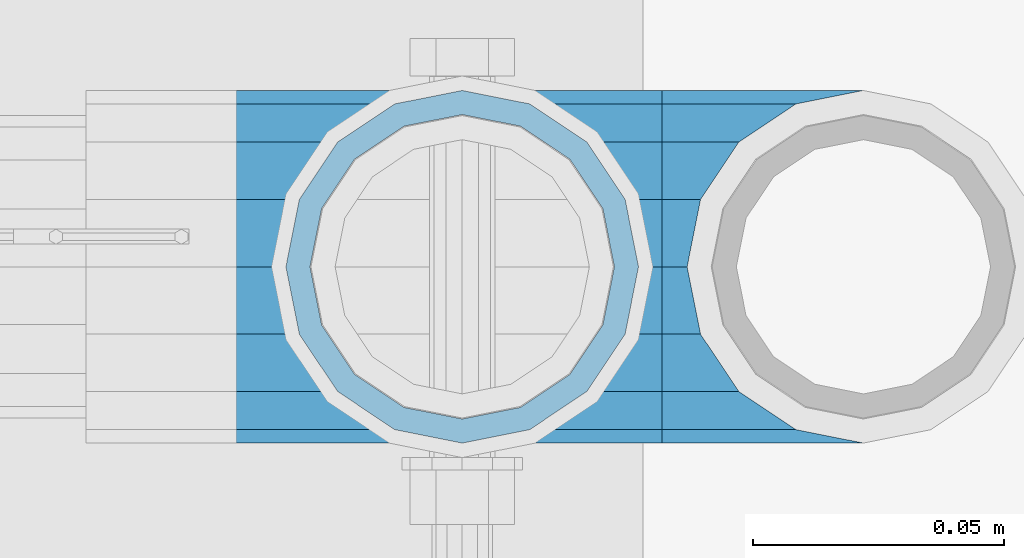
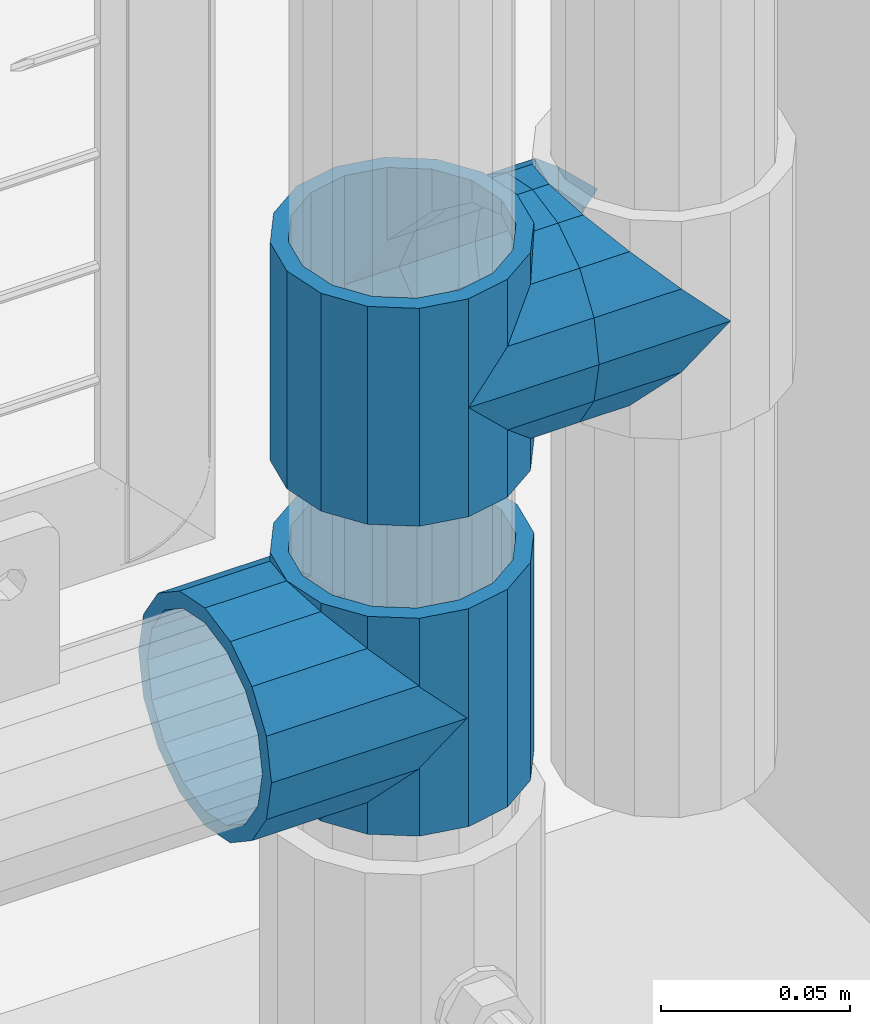
# One storey, part 171 of 247: 5 beams.
"""IFC2X3 building model written with IfcOpenShell, lengths in millimetres."""

from ifc_helpers import new_model, si_unit, frame, origin_with_axes, place, context, subcontext, project, spatial, faceted_brep, material, type_object, element, save


model = new_model("IFC2X3")

# Units and contexts
model_context = context("Model", 3, precision=1e-05, world=origin_with_axes())
body_context = subcontext(model_context, "Body", "Model", "MODEL_VIEW")
ifc_project = project(units=[si_unit("LENGTHUNIT", "METRE", prefix="MILLI"), si_unit("AREAUNIT", "SQUARE_METRE"), si_unit("VOLUMEUNIT", "CUBIC_METRE"), si_unit("MASSUNIT", "GRAM", prefix="KILO"), si_unit("TIMEUNIT", "SECOND"), si_unit("PLANEANGLEUNIT", "RADIAN"), si_unit("SOLIDANGLEUNIT", "STERADIAN"), si_unit("THERMODYNAMICTEMPERATUREUNIT", "DEGREE_CELSIUS"), si_unit("LUMINOUSINTENSITYUNIT", "LUMEN")], contexts=[model_context])

# Site, building, storey
site_placement = place(None, origin_with_axes())
site = spatial("IfcSite", under=ifc_project, at=site_placement, CompositionType="ELEMENT")
building_placement = place(site_placement, origin_with_axes())
building = spatial("IfcBuilding", under=site, at=building_placement, Name="Standard", CompositionType="ELEMENT")
storey_placement = place(building_placement, origin_with_axes())
storey = spatial("IfcBuildingStorey", under=building, at=storey_placement, Name="Undefined", CompositionType="ELEMENT", Elevation=0.0)

# Beams
ifc_material = material(Name="Misc_Undefined")
beam_type = type_object("IfcBeamType", PredefinedType="NOTDEFINED")
beam_1_placement = place(storey_placement, frame((16221.0, 7664.5, 298.670000000001), z_axis=(0.0, 1.0, 0.0), x_axis=(-1.0, 0.0, 0.0)))
element("IfcBeam", 1, at=beam_1_placement, inside=storey, type_object=beam_type, material=ifc_material, context=body_context, shape_type="Brep", body=[
    faceted_brep([(0.0, 0.0, -35.1499999999996), (13.4513226476338, -13.4513226476329, -32.4743655677721), (13.4513226476338, 13.4513226476329, -32.4743655677721), (27.1226768591096, -21.4606908090117, 21.4606908090118), (32.4743655677721, -26.8123795176755, 13.4513226476329), (32.4743655677721, -32.4743655677717, 13.4513226476329), (24.8548033587067, -24.8548033587072, 24.8548033587067), (24.8548033587067, -16.3810424080045, 24.8548033587067), (32.8397438117172, -28.0397438117175, 11.6144421722802), (35.1499999999996, -30.35, 0.0), (35.1499999999996, -35.15, 0.0), (32.4743655677721, -26.8123795176766, -13.4513226476329), (32.4743655677721, -32.4743655677717, -13.4513226476329), (32.8397438117172, -28.0397438117175, -11.6144421722802), (24.8548033587067, -16.3810424080045, -24.8548033587067), (24.8548033587067, -24.8548033587072, -24.8548033587067), (27.1226768591059, -21.4606908090117, -21.4606908090118), (20.0882031229885, -11.6144421722805, -28.0397438117179), (16.6306603983739, 0.0, -30.3500000000004), (20.0882031229885, 11.6144421722805, -28.0397438117179), (24.8548033587067, 16.3810424080029, -24.8548033587067), (24.8548033587067, 24.8548033587072, -24.8548033587067), (27.1226768591059, 21.4606908090117, -21.4606908090118), (32.4743655677721, 26.8123795176755, -13.4513226476329), (32.4743655677721, 32.4743655677717, -13.4513226476329), (32.8397438117172, 28.0397438117175, -11.6144421722802), (35.1499999999996, 30.35, 0.0), (35.1499999999996, 35.15, 0.0), (32.8397438117172, 28.0397438117175, 11.6144421722802), (32.4743655677721, 26.8123795176755, 13.4513226476329), (32.4743655677721, 32.4743655677717, 13.4513226476329), (27.1226768591096, 21.4606908090117, 21.4606908090118), (24.8548033587067, 16.3810424080046, 24.8548033587067), (24.8548033587067, 24.8548033587072, 24.8548033587067), (0.0, 0.0, 35.1499999999996), (13.4513226476338, 13.4513226476329, 32.4743655677721), (13.4513226476338, -13.4513226476329, 32.4743655677721), (20.0882031229812, 11.6144421722805, 28.0397438117179), (16.6306603983649, 0.0, 30.3500000000004), (20.0882031229812, -11.6144421722805, 28.0397438117179), (60.1499999999996, -35.15, 0.0), (60.1499999999996, -32.4743655677717, 13.4513226476329), (60.1499999999996, -24.8548033587072, 24.8548033587067), (60.1499999999996, -13.4513226476329, 32.4743655677721), (60.1499999999996, 0.0, 35.1499999999996), (60.1499999999996, -24.8548033587072, -24.8548033587067), (60.1499999999996, -32.4743655677717, -13.4513226476329), (60.1499999999996, -13.4513226476329, -32.4743655677721), (60.1499999999996, 0.0, -35.1499999999996), (60.1499999999996, 13.4513226476329, -32.4743655677721), (60.1499999999996, 24.8548033587072, -24.8548033587067), (60.1499999999996, 32.4743655677717, -13.4513226476329), (60.1499999999996, 35.15, 0.0), (60.1499999999996, 32.4743655677717, 13.4513226476329), (60.1499999999996, 24.8548033587072, 24.8548033587067), (60.1499999999996, 13.4513226476329, 32.4743655677721), (60.1499999999996, -21.4606908090117, 21.4606908090118), (60.1499999999996, -11.6144421722805, 28.0397438117179), (60.1499999999996, 0.0, 30.3500000000004), (60.1499999999996, 11.6144421722805, 28.0397438117179), (60.1499999999996, 21.4606908090117, 21.4606908090118), (60.1499999999996, 28.0397438117175, 11.6144421722802), (60.1499999999996, 30.35, 0.0), (60.1499999999996, 28.0397438117175, -11.6144421722802), (60.1499999999996, 21.4606908090117, -21.4606908090118), (60.1499999999996, 11.6144421722805, -28.0397438117179), (60.1499999999996, 0.0, -30.3500000000004), (60.1499999999996, -11.6144421722805, -28.0397438117179), (60.1499999999996, -21.4606908090117, -21.4606908090118), (60.1499999999996, -28.0397438117175, -11.6144421722802), (60.1499999999996, -30.35, 0.0), (60.1499999999996, -28.0397438117175, 11.6144421722802)], [[[0, 1, 2]], [[3, 4, 5, 6, 7]], [[8, 9, 10, 5, 4]], [[11, 12, 10, 9, 13]], [[14, 15, 12, 11, 16]], [[2, 1, 15, 14, 17, 18, 19, 20, 21]], [[21, 20, 22, 23, 24]], [[24, 23, 25, 26, 27]], [[27, 26, 28, 29, 30]], [[30, 29, 31, 32, 33]], [[34, 35, 36]], [[33, 32, 37, 38, 39, 7, 6, 36, 35]], [[40, 41, 5, 10]], [[41, 42, 6, 5]], [[42, 43, 36, 6]], [[43, 44, 34, 36]], [[45, 46, 12, 15]], [[47, 45, 15, 1]], [[48, 47, 1, 0]], [[49, 48, 0, 2]], [[50, 49, 2, 21]], [[51, 50, 21, 24]], [[52, 51, 24, 27]], [[53, 52, 27, 30]], [[54, 53, 30, 33]], [[55, 54, 33, 35]], [[44, 55, 35, 34]], [[46, 40, 10, 12]], [[45, 47, 48, 49, 50, 51, 52, 53, 54, 55, 44, 43, 42, 41, 40, 46], [56, 57, 58, 59, 60, 61, 62, 63, 64, 65, 66, 67, 68, 69, 70, 71]], [[59, 58, 38, 37]], [[31, 60, 59, 37, 32]], [[28, 61, 60, 31, 29]], [[62, 61, 28, 26]], [[63, 62, 26, 25]], [[64, 63, 25, 23, 22]], [[65, 64, 22, 20, 19]], [[66, 65, 19, 18]], [[67, 66, 18, 17]], [[16, 68, 67, 17, 14]], [[13, 69, 68, 16, 11]], [[70, 69, 13, 9]], [[71, 70, 9, 8]], [[56, 71, 8, 4, 3]], [[57, 56, 3, 7, 39]], [[58, 57, 39, 38]]]),
])
beam_2_placement = place(storey_placement, frame((16221.0, 7664.5, 333.820000000001), z_axis=(1.0, 0.0, 0.0), x_axis=(0.0, 0.0, -1.0)))
element("IfcBeam", 2, at=beam_2_placement, inside=storey, type_object=beam_type, material=ifc_material, context=body_context, shape_type="Brep", body=[
    faceted_brep([(46.7644421722801, 28.0397438117179, -11.6144421722802), (46.7644421722801, 28.0397438117179, -20.088203122983), (51.5310424080055, 24.8548033587067, -24.8548033587067), (56.6106908090114, 21.4606908090118, -27.1226768591096), (56.6106908090114, 21.4606908090118, -21.4606908090118), (61.9623795176755, 13.4513226476329, -32.4743655677721), (63.1897438117172, 11.6144421722802, -32.839743811719), (63.1897438117172, 11.6144421722802, -28.0397438117179), (65.4999999999997, 0.0, -35.1499999999996), (65.4999999999997, 0.0, -30.3500000000004), (63.1897438117172, -11.6144421722802, -32.839743811719), (63.1897438117172, -11.6144421722802, -28.0397438117179), (61.9623795176754, -13.4513226476329, -32.4743655677721), (56.6106908090114, -21.4606908090118, -27.1226768591077), (56.6106908090114, -21.4606908090118, -21.4606908090118), (51.5310424080038, -24.8548033587067, -24.8548033587067), (46.7644421722801, -28.0397438117179, -20.0882031229885), (46.7644421722801, -28.0397438117179, -11.6144421722802), (35.1499999999996, -30.3500000000004, -16.6306603983739), (35.1499999999996, -30.35, 0.0), (23.5355578277191, -28.0397438117179, -20.0882031229885), (23.5355578277191, -28.0397438117179, -11.6144421722802), (18.768957591997, -24.8548033587067, -24.8548033587067), (13.6893091909879, -21.4606908090118, -27.1226768591077), (13.6893091909879, -21.4606908090118, -21.4606908090118), (8.33762048232325, -13.4513226476329, -32.4743655677721), (7.11025618828211, -11.6144421722802, -32.839743811719), (7.11025618828211, -11.6144421722802, -28.0397438117179), (4.79999999999961, 0.0, -35.1499999999996), (4.79999999999961, 0.0, -30.3500000000004), (7.11025618828211, 11.6144421722802, -32.839743811719), (7.11025618828211, 11.6144421722802, -28.0397438117179), (8.33762048232387, 13.4513226476329, -32.4743655677721), (13.6893091909879, 21.4606908090118, -27.1226768591096), (13.6893091909879, 21.4606908090118, -21.4606908090118), (18.768957591997, 24.8548033587067, -24.8548033587067), (23.5355578277192, 28.0397438117179, -20.088203122983), (23.5355578277192, 28.0397438117179, -11.6144421722802), (35.1499999999996, 30.3500000000004, -16.6306603983649), (35.1499999999996, 30.35, 0.0), (0.0, 32.4743655677721, -13.4513226476338), (0.0, 35.1499999999996, 0.0), (70.2999999999993, 35.1499999999996, 0.0), (70.2999999999993, 32.4743655677721, -13.4513226476338), (0.0, 32.4743655677721, 13.4513226476338), (70.2999999999993, 32.4743655677721, 13.4513226476338), (0.0, 24.8548033587067, 24.8548033587067), (70.2999999999993, 24.8548033587067, 24.8548033587067), (0.0, 13.4513226476329, 32.4743655677721), (70.2999999999993, 13.4513226476329, 32.4743655677721), (0.0, 0.0, 35.1499999999996), (70.2999999999993, 0.0, 35.1499999999996), (0.0, -13.4513226476329, 32.4743655677721), (70.2999999999993, -13.4513226476329, 32.4743655677721), (0.0, -24.8548033587067, 24.8548033587067), (70.2999999999993, -24.8548033587067, 24.8548033587067), (0.0, -32.4743655677721, 13.4513226476338), (70.2999999999993, -32.4743655677721, 13.4513226476338), (0.0, -35.1499999999996, 0.0), (70.2999999999993, -35.1499999999996, 0.0), (70.2999999999993, -30.3500000000004, 0.0), (70.2999999999993, -28.0397438117179, -11.6144421722802), (70.2999999999993, -21.4606908090118, -21.4606908090118), (70.2999999999993, -11.6144421722802, -28.0397438117179), (70.2999999999993, 0.0, -30.3500000000004), (70.2999999999993, 11.6144421722802, -28.0397438117179), (70.2999999999993, 21.4606908090118, -21.4606908090118), (70.2999999999993, 28.0397438117179, -11.6144421722802), (0.0, -28.0397438117179, -11.6144421722802), (0.0, -30.3500000000004, 0.0), (0.0, -21.4606908090118, -21.4606908090118), (0.0, -11.6144421722802, -28.0397438117179), (0.0, 0.0, -30.3500000000004), (0.0, 11.6144421722802, -28.0397438117179), (0.0, 21.4606908090118, -21.4606908090118), (0.0, 28.0397438117179, -11.6144421722802), (0.0, 30.3500000000004, 0.0), (70.2999999999993, 30.3500000000004, 0.0), (0.0, 28.0397438117179, 11.6144421722802), (70.2999999999993, 28.0397438117179, 11.6144421722802), (0.0, 21.4606908090118, 21.4606908090118), (70.2999999999993, 21.4606908090118, 21.4606908090118), (0.0, 11.6144421722802, 28.0397438117179), (70.2999999999993, 11.6144421722802, 28.0397438117179), (0.0, 0.0, 30.3500000000004), (70.2999999999993, 0.0, 30.3500000000004), (0.0, -11.6144421722802, 28.0397438117179), (70.2999999999993, -11.6144421722802, 28.0397438117179), (0.0, -21.4606908090118, 21.4606908090118), (70.2999999999993, -21.4606908090118, 21.4606908090118), (0.0, -28.0397438117179, 11.6144421722802), (70.2999999999993, -28.0397438117179, 11.6144421722802), (70.2999999999993, -24.8548033587067, -24.8548033587067), (70.2999999999993, -13.4513226476329, -32.4743655677721), (70.2999999999993, 0.0, -35.1499999999996), (70.2999999999993, 13.4513226476329, -32.4743655677721), (70.2999999999993, 24.8548033587067, -24.8548033587067), (70.2999999999993, -32.4743655677721, -13.4513226476338), (0.0, -32.4743655677721, -13.4513226476338), (0.0, 24.8548033587067, -24.8548033587067), (0.0, 13.4513226476329, -32.4743655677721), (0.0, 0.0, -35.1499999999996), (0.0, -13.4513226476329, -32.4743655677721), (0.0, -24.8548033587067, -24.8548033587067)], [[[0, 1, 2, 3, 4]], [[4, 3, 5, 6, 7]], [[7, 6, 8, 9]], [[9, 8, 10, 11]], [[11, 10, 12, 13, 14]], [[14, 13, 15, 16, 17]], [[17, 16, 18, 19]], [[19, 18, 20, 21]], [[21, 20, 22, 23, 24]], [[24, 23, 25, 26, 27]], [[27, 26, 28, 29]], [[29, 28, 30, 31]], [[31, 30, 32, 33, 34]], [[34, 33, 35, 36, 37]], [[37, 36, 38, 39]], [[39, 38, 1, 0]], [[40, 41, 42, 43]], [[41, 44, 45, 42]], [[44, 46, 47, 45]], [[46, 48, 49, 47]], [[48, 50, 51, 49]], [[50, 52, 53, 51]], [[52, 54, 55, 53]], [[54, 56, 57, 55]], [[56, 58, 59, 57]], [[60, 61, 17, 19]], [[61, 62, 14, 17]], [[62, 63, 11, 14]], [[63, 64, 9, 11]], [[64, 65, 7, 9]], [[65, 66, 4, 7]], [[66, 67, 0, 4]], [[68, 69, 19, 21]], [[70, 68, 21, 24]], [[71, 70, 24, 27]], [[72, 71, 27, 29]], [[73, 72, 29, 31]], [[74, 73, 31, 34]], [[75, 74, 34, 37]], [[76, 75, 37, 39]], [[67, 77, 39, 0]], [[78, 76, 39, 77, 79]], [[80, 78, 79, 81]], [[82, 80, 81, 83]], [[84, 82, 83, 85]], [[86, 84, 85, 87]], [[88, 86, 87, 89]], [[90, 88, 89, 91]], [[19, 69, 90, 91, 60]], [[92, 93, 94, 95, 96, 43, 42, 45, 47, 49, 51, 53, 55, 57, 59, 97], [89, 87, 85, 83, 81, 79, 77, 67, 66, 65, 64, 63, 62, 61, 60, 91]], [[58, 98, 97, 59]], [[56, 54, 52, 50, 48, 46, 44, 41, 40, 99, 100, 101, 102, 103, 98, 58], [68, 70, 71, 72, 73, 74, 75, 76, 78, 80, 82, 84, 86, 88, 90, 69]], [[32, 100, 99, 35, 33]], [[28, 101, 100, 32, 30]], [[102, 101, 28, 26, 25]], [[103, 102, 25, 23, 22]], [[15, 92, 97, 98, 103, 22, 20, 18, 16]], [[12, 93, 92, 15, 13]], [[8, 94, 93, 12, 10]], [[95, 94, 8, 6, 5]], [[96, 95, 5, 3, 2]], [[35, 99, 40, 43, 96, 2, 1, 38, 36]]]),
])
beam_3_placement = place(storey_placement, frame((16221.0, 7664.5, 398.669999999999), z_axis=(0.0, -0.999999999999548, -9.5100000000016e-07), x_axis=(1.0, 0.0, 0.0)))
element("IfcBeam", 3, at=beam_3_placement, inside=storey, type_object=beam_type, material=ifc_material, context=body_context, shape_type="Brep", body=[
    faceted_brep([(0.0, 0.0, -35.1499999999996), (13.4513226476338, -13.4513226476329, -32.4743655677721), (13.4513226476338, 13.4513226476329, -32.4743655677721), (32.4743655677721, 32.4743655677717, 13.4513226476329), (32.4743655677721, 26.8123795176755, 13.4513226476329), (27.1226768591096, 21.4606908090117, 21.4606908090118), (24.8548033587067, 16.3810424080046, 24.8548033587067), (24.8548033587067, 24.8548033587072, 24.8548033587067), (0.0, 0.0, 35.1499999999996), (13.4513226476338, 13.4513226476329, 32.4743655677721), (13.4513226476338, -13.4513226476329, 32.4743655677721), (20.0882031229812, 11.6144421722805, 28.0397438117179), (16.6306603983649, 0.0, 30.3500000000004), (20.0882031229812, -11.6144421722805, 28.0397438117179), (24.8548033587067, -16.3810424080045, 24.8548033587067), (24.8548033587067, -24.8548033587072, 24.8548033587067), (27.1226768591096, -21.4606908090117, 21.4606908090118), (32.4743655677721, -26.8123795176755, 13.4513226476329), (32.4743655677721, -32.4743655677717, 13.4513226476329), (32.8397438117172, -28.0397438117175, 11.6144421722802), (35.1499999999996, -30.35, 0.0), (35.1499999999996, -35.15, 0.0), (32.4743655677721, -26.8123795176766, -13.4513226476329), (32.4743655677721, -32.4743655677717, -13.4513226476329), (32.8397438117172, -28.0397438117175, -11.6144421722802), (24.8548033587067, -16.3810424080045, -24.8548033587067), (24.8548033587067, -24.8548033587072, -24.8548033587067), (27.1226768591059, -21.4606908090117, -21.4606908090118), (20.0882031229885, -11.6144421722805, -28.0397438117179), (16.6306603983739, 0.0, -30.3500000000004), (20.0882031229885, 11.6144421722805, -28.0397438117179), (24.8548033587067, 16.3810424080029, -24.8548033587067), (24.8548033587067, 24.8548033587072, -24.8548033587067), (27.1226768591059, 21.4606908090117, -21.4606908090118), (32.4743655677721, 26.8123795176755, -13.4513226476329), (32.4743655677721, 32.4743655677717, -13.4513226476329), (32.8397438117172, 28.0397438117175, -11.6144421722802), (35.1499999999996, 30.35, 0.0), (35.1499999999996, 35.15, 0.0), (32.8397438117172, 28.0397438117175, 11.6144421722802), (40.1500000000015, -35.15, 0.0), (40.1500000000015, -32.4743655677717, 13.4513226476329), (40.1500000000015, -24.8548033587072, 24.8548033587067), (40.1500000000015, -13.4513226476329, 32.4743655677721), (40.1500000000015, 0.0, 35.1499999999996), (40.1500000000015, 13.4513226476329, 32.4743655677721), (40.1500000000015, 24.8548033587072, 24.8548033587067), (40.1500000000015, 32.4743655677717, 13.4513226476329), (40.1500000000015, 35.15, 0.0), (40.1500000000015, -24.8548033587072, -24.8548033587067), (40.1500000000015, -32.4743655677717, -13.4513226476329), (40.1500000000015, -13.4513226476329, -32.4743655677721), (40.1500000000015, 0.0, -35.1499999999996), (40.1500000000015, 13.4513226476329, -32.4743655677721), (40.1500000000015, 24.8548033587072, -24.8548033587067), (40.1500000000015, 32.4743655677717, -13.4513226476329), (40.1500000000015, -21.4606908090117, 21.4606908090118), (40.1500000000015, -11.6144421722805, 28.0397438117179), (40.1500000000015, 0.0, 30.3500000000004), (40.1500000000015, 11.6144421722805, 28.0397438117179), (40.1500000000015, 21.4606908090117, 21.4606908090118), (40.1500000000015, 28.0397438117175, 11.6144421722802), (40.1500000000015, 30.35, 0.0), (40.1500000000015, 28.0397438117175, -11.6144421722802), (40.1500000000015, 21.4606908090117, -21.4606908090118), (40.1500000000015, 11.6144421722805, -28.0397438117179), (40.1500000000015, 0.0, -30.3500000000004), (40.1500000000015, -11.6144421722805, -28.0397438117179), (40.1500000000015, -21.4606908090117, -21.4606908090118), (40.1500000000015, -28.0397438117175, -11.6144421722802), (40.1500000000015, -30.35, 0.0), (40.1500000000015, -28.0397438117175, 11.6144421722802)], [[[0, 1, 2]], [[3, 4, 5, 6, 7]], [[8, 9, 10]], [[7, 6, 11, 12, 13, 14, 15, 10, 9]], [[16, 17, 18, 15, 14]], [[19, 20, 21, 18, 17]], [[22, 23, 21, 20, 24]], [[25, 26, 23, 22, 27]], [[2, 1, 26, 25, 28, 29, 30, 31, 32]], [[32, 31, 33, 34, 35]], [[35, 34, 36, 37, 38]], [[38, 37, 39, 4, 3]], [[40, 41, 18, 21]], [[41, 42, 15, 18]], [[42, 43, 10, 15]], [[43, 44, 8, 10]], [[44, 45, 9, 8]], [[45, 46, 7, 9]], [[46, 47, 3, 7]], [[47, 48, 38, 3]], [[49, 50, 23, 26]], [[51, 49, 26, 1]], [[52, 51, 1, 0]], [[53, 52, 0, 2]], [[54, 53, 2, 32]], [[55, 54, 32, 35]], [[48, 55, 35, 38]], [[50, 40, 21, 23]], [[49, 51, 52, 53, 54, 55, 48, 47, 46, 45, 44, 43, 42, 41, 40, 50], [56, 57, 58, 59, 60, 61, 62, 63, 64, 65, 66, 67, 68, 69, 70, 71]], [[63, 62, 37, 36]], [[33, 64, 63, 36, 34]], [[30, 65, 64, 33, 31]], [[66, 65, 30, 29]], [[67, 66, 29, 28]], [[68, 67, 28, 25, 27]], [[69, 68, 27, 22, 24]], [[70, 69, 24, 20]], [[71, 70, 20, 19]], [[16, 56, 71, 19, 17]], [[13, 57, 56, 16, 14]], [[58, 57, 13, 12]], [[59, 58, 12, 11]], [[60, 59, 11, 6, 5]], [[61, 60, 5, 4, 39]], [[62, 61, 39, 37]]]),
])
beam_4_placement = place(storey_placement, frame((16301.0, 7664.5, 398.669999999999), z_axis=(0.0, 1.0, 0.0), x_axis=(-1.0, 0.0, 0.0)))
element("IfcBeam", 4, at=beam_4_placement, inside=storey, type_object=beam_type, material=ifc_material, context=body_context, shape_type="Brep", body=[
    faceted_brep([(0.0, 0.0, -35.1499999999996), (13.4513226476338, -13.4513226476329, -32.4743655677721), (13.4513226476338, 13.4513226476329, -32.4743655677721), (27.1226768591096, -21.4606908090117, 21.4606908090118), (32.4743655677721, -26.8123795176755, 13.4513226476329), (32.4743655677721, -32.4743655677717, 13.4513226476329), (24.8548033587067, -24.8548033587072, 24.8548033587067), (24.8548033587067, -16.3810424080045, 24.8548033587067), (32.8397438117172, -28.0397438117175, 11.6144421722802), (35.1499999999996, -30.35, 0.0), (35.1499999999996, -35.15, 0.0), (32.4743655677721, -26.8123795176766, -13.4513226476329), (32.4743655677721, -32.4743655677717, -13.4513226476329), (32.8397438117172, -28.0397438117175, -11.6144421722802), (24.8548033587067, -16.3810424080045, -24.8548033587067), (24.8548033587067, -24.8548033587072, -24.8548033587067), (27.1226768591059, -21.4606908090117, -21.4606908090118), (20.0882031229885, -11.6144421722805, -28.0397438117179), (16.6306603983739, 0.0, -30.3500000000004), (20.0882031229885, 11.6144421722805, -28.0397438117179), (24.8548033587067, 16.3810424080029, -24.8548033587067), (24.8548033587067, 24.8548033587072, -24.8548033587067), (27.1226768591059, 21.4606908090117, -21.4606908090118), (32.4743655677721, 26.8123795176755, -13.4513226476329), (32.4743655677721, 32.4743655677717, -13.4513226476329), (32.8397438117172, 28.0397438117175, -11.6144421722802), (35.1499999999996, 30.35, 0.0), (35.1499999999996, 35.15, 0.0), (32.8397438117172, 28.0397438117175, 11.6144421722802), (32.4743655677721, 26.8123795176755, 13.4513226476329), (32.4743655677721, 32.4743655677717, 13.4513226476329), (27.1226768591096, 21.4606908090117, 21.4606908090118), (24.8548033587067, 16.3810424080046, 24.8548033587067), (24.8548033587067, 24.8548033587072, 24.8548033587067), (0.0, 0.0, 35.1499999999996), (13.4513226476338, 13.4513226476329, 32.4743655677721), (13.4513226476338, -13.4513226476329, 32.4743655677721), (20.0882031229812, 11.6144421722805, 28.0397438117179), (16.6306603983649, 0.0, 30.3500000000004), (20.0882031229812, -11.6144421722805, 28.0397438117179), (40.1500000000015, -35.15, 0.0), (40.1500000000015, -32.4743655677717, 13.4513226476329), (40.1500000000015, -24.8548033587072, 24.8548033587067), (40.1500000000015, -13.4513226476329, 32.4743655677721), (40.1500000000015, 0.0, 35.1499999999996), (40.1500000000015, -24.8548033587072, -24.8548033587067), (40.1500000000015, -32.4743655677717, -13.4513226476329), (40.1500000000015, -13.4513226476329, -32.4743655677721), (40.1500000000015, 0.0, -35.1499999999996), (40.1500000000015, 13.4513226476329, -32.4743655677721), (40.1500000000015, 24.8548033587072, -24.8548033587067), (40.1500000000015, 32.4743655677717, -13.4513226476329), (40.1500000000015, 35.15, 0.0), (40.1500000000015, 32.4743655677717, 13.4513226476329), (40.1500000000015, 24.8548033587072, 24.8548033587067), (40.1500000000015, 13.4513226476329, 32.4743655677721), (40.1500000000015, -21.4606908090117, 21.4606908090118), (40.1500000000015, -11.6144421722805, 28.0397438117179), (40.1500000000015, 0.0, 30.3500000000004), (40.1500000000015, 11.6144421722805, 28.0397438117179), (40.1500000000015, 21.4606908090117, 21.4606908090118), (40.1500000000015, 28.0397438117175, 11.6144421722802), (40.1500000000015, 30.35, 0.0), (40.1500000000015, 28.0397438117175, -11.6144421722802), (40.1500000000015, 21.4606908090117, -21.4606908090118), (40.1500000000015, 11.6144421722805, -28.0397438117179), (40.1500000000015, 0.0, -30.3500000000004), (40.1500000000015, -11.6144421722805, -28.0397438117179), (40.1500000000015, -21.4606908090117, -21.4606908090118), (40.1500000000015, -28.0397438117175, -11.6144421722802), (40.1500000000015, -30.35, 0.0), (40.1500000000015, -28.0397438117175, 11.6144421722802)], [[[0, 1, 2]], [[3, 4, 5, 6, 7]], [[8, 9, 10, 5, 4]], [[11, 12, 10, 9, 13]], [[14, 15, 12, 11, 16]], [[2, 1, 15, 14, 17, 18, 19, 20, 21]], [[21, 20, 22, 23, 24]], [[24, 23, 25, 26, 27]], [[27, 26, 28, 29, 30]], [[30, 29, 31, 32, 33]], [[34, 35, 36]], [[33, 32, 37, 38, 39, 7, 6, 36, 35]], [[40, 41, 5, 10]], [[41, 42, 6, 5]], [[42, 43, 36, 6]], [[43, 44, 34, 36]], [[45, 46, 12, 15]], [[47, 45, 15, 1]], [[48, 47, 1, 0]], [[49, 48, 0, 2]], [[50, 49, 2, 21]], [[51, 50, 21, 24]], [[52, 51, 24, 27]], [[53, 52, 27, 30]], [[54, 53, 30, 33]], [[55, 54, 33, 35]], [[44, 55, 35, 34]], [[46, 40, 10, 12]], [[45, 47, 48, 49, 50, 51, 52, 53, 54, 55, 44, 43, 42, 41, 40, 46], [56, 57, 58, 59, 60, 61, 62, 63, 64, 65, 66, 67, 68, 69, 70, 71]], [[59, 58, 38, 37]], [[60, 59, 37, 32, 31]], [[61, 60, 31, 29, 28]], [[62, 61, 28, 26]], [[63, 62, 26, 25]], [[22, 64, 63, 25, 23]], [[19, 65, 64, 22, 20]], [[66, 65, 19, 18]], [[67, 66, 18, 17]], [[68, 67, 17, 14, 16]], [[69, 68, 16, 11, 13]], [[70, 69, 13, 9]], [[71, 70, 9, 8]], [[3, 56, 71, 8, 4]], [[39, 57, 56, 3, 7]], [[58, 57, 39, 38]]]),
])
beam_5_placement = place(storey_placement, frame((16221.0, 7664.5, 433.819999999999), z_axis=(-1.0, 0.0, 0.0), x_axis=(0.0, 0.0, -1.0)))
element("IfcBeam", 5, at=beam_5_placement, inside=storey, type_object=beam_type, material=ifc_material, context=body_context, shape_type="Brep", body=[
    faceted_brep([(13.6893091909879, -21.4606908090118, -21.4606908090118), (13.6893091909879, -21.4606908090118, -27.1226768591077), (8.33762048232325, -13.4513226476329, -32.4743655677721), (7.11025618828211, -11.6144421722802, -32.839743811719), (7.11025618828211, -11.6144421722802, -28.0397438117179), (23.5355578277191, -28.0397438117179, -11.6144421722802), (23.5355578277191, -28.0397438117179, -20.0882031229885), (18.768957591997, -24.8548033587067, -24.8548033587067), (35.1499999999996, -30.35, 0.0), (35.1499999999996, -30.3500000000004, -16.6306603983739), (46.7644421722801, -28.0397438117179, -11.6144421722802), (46.7644421722801, -28.0397438117179, -20.0882031229885), (56.6106908090114, -21.4606908090118, -21.4606908090118), (56.6106908090114, -21.4606908090118, -27.1226768591077), (51.5310424080038, -24.8548033587067, -24.8548033587067), (63.1897438117172, -11.6144421722802, -28.0397438117179), (63.1897438117172, -11.6144421722802, -32.839743811719), (61.9623795176754, -13.4513226476329, -32.4743655677721), (65.4999999999997, 0.0, -30.3500000000004), (65.4999999999997, 0.0, -35.1499999999996), (63.1897438117172, 11.6144421722802, -28.0397438117179), (63.1897438117172, 11.6144421722802, -32.839743811719), (56.6106908090114, 21.4606908090118, -21.4606908090118), (56.6106908090114, 21.4606908090118, -27.1226768591096), (61.9623795176755, 13.4513226476329, -32.4743655677721), (46.7644421722801, 28.0397438117179, -11.6144421722802), (46.7644421722801, 28.0397438117179, -20.088203122983), (51.5310424080055, 24.8548033587067, -24.8548033587067), (35.1499999999996, 30.35, 0.0), (35.1499999999996, 30.3500000000004, -16.6306603983649), (23.5355578277192, 28.0397438117179, -11.6144421722802), (23.5355578277192, 28.0397438117179, -20.088203122983), (13.6893091909879, 21.4606908090118, -21.4606908090118), (13.6893091909879, 21.4606908090118, -27.1226768591096), (18.768957591997, 24.8548033587067, -24.8548033587067), (7.11025618828211, 11.6144421722802, -28.0397438117179), (7.11025618828211, 11.6144421722802, -32.839743811719), (8.33762048232387, 13.4513226476329, -32.4743655677721), (4.79999999999961, 0.0, -30.3500000000004), (4.79999999999961, 0.0, -35.1499999999996), (0.0, 21.4606908090118, 21.4606908090118), (0.0, 28.0397438117179, 11.6144421722802), (70.2999999999993, 28.0397438117179, 11.6144421722802), (70.2999999999993, 21.4606908090118, 21.4606908090118), (0.0, 11.6144421722802, 28.0397438117179), (70.2999999999993, 11.6144421722802, 28.0397438117179), (0.0, 0.0, 30.3500000000004), (70.2999999999993, 0.0, 30.3500000000004), (0.0, -11.6144421722802, 28.0397438117179), (70.2999999999993, -11.6144421722802, 28.0397438117179), (0.0, -21.4606908090118, 21.4606908090118), (70.2999999999993, -21.4606908090118, 21.4606908090118), (0.0, -28.0397438117179, 11.6144421722802), (70.2999999999993, -28.0397438117179, 11.6144421722802), (0.0, -24.8548033587067, -24.8548033587067), (0.0, -13.4513226476329, -32.4743655677721), (0.0, 0.0, -35.1499999999996), (0.0, -32.4743655677721, 13.4513226476338), (0.0, -35.1499999999996, 0.0), (70.2999999999993, -35.1499999999996, 0.0), (70.2999999999993, -32.4743655677721, 13.4513226476338), (0.0, -24.8548033587067, 24.8548033587067), (70.2999999999993, -24.8548033587067, 24.8548033587067), (0.0, -13.4513226476329, 32.4743655677721), (70.2999999999993, -13.4513226476329, 32.4743655677721), (0.0, 0.0, 35.1499999999996), (70.2999999999993, 0.0, 35.1499999999996), (0.0, 13.4513226476329, 32.4743655677721), (70.2999999999993, 13.4513226476329, 32.4743655677721), (0.0, 24.8548033587067, 24.8548033587067), (70.2999999999993, 24.8548033587067, 24.8548033587067), (0.0, 32.4743655677721, 13.4513226476338), (70.2999999999993, 32.4743655677721, 13.4513226476338), (0.0, 35.1499999999996, 0.0), (70.2999999999993, 35.1499999999996, 0.0), (0.0, 32.4743655677721, -13.4513226476338), (70.2999999999993, 32.4743655677721, -13.4513226476338), (70.2999999999993, -13.4513226476329, -32.4743655677721), (70.2999999999993, -24.8548033587067, -24.8548033587067), (70.2999999999993, 0.0, -35.1499999999996), (70.2999999999993, 13.4513226476329, -32.4743655677721), (70.2999999999993, 24.8548033587067, -24.8548033587067), (0.0, 24.8548033587067, -24.8548033587067), (0.0, 13.4513226476329, -32.4743655677721), (70.2999999999993, -32.4743655677721, -13.4513226476338), (0.0, -32.4743655677721, -13.4513226476338), (0.0, -28.0397438117179, -11.6144421722802), (0.0, -21.4606908090118, -21.4606908090118), (0.0, -11.6144421722802, -28.0397438117179), (0.0, 0.0, -30.3500000000004), (0.0, 11.6144421722802, -28.0397438117179), (0.0, 21.4606908090118, -21.4606908090118), (0.0, 28.0397438117179, -11.6144421722802), (0.0, 30.3500000000004, 0.0), (0.0, -30.3500000000004, 0.0), (70.2999999999993, 30.3500000000004, 0.0), (70.2999999999993, 28.0397438117179, -11.6144421722802), (70.2999999999993, 21.4606908090118, -21.4606908090118), (70.2999999999993, 11.6144421722802, -28.0397438117179), (70.2999999999993, 0.0, -30.3500000000004), (70.2999999999993, -11.6144421722802, -28.0397438117179), (70.2999999999993, -21.4606908090118, -21.4606908090118), (70.2999999999993, -28.0397438117179, -11.6144421722802), (70.2999999999993, -30.3500000000004, 0.0)], [[[0, 1, 2, 3, 4]], [[5, 6, 7, 1, 0]], [[8, 9, 6, 5]], [[10, 11, 9, 8]], [[12, 13, 14, 11, 10]], [[15, 16, 17, 13, 12]], [[18, 19, 16, 15]], [[20, 21, 19, 18]], [[22, 23, 24, 21, 20]], [[25, 26, 27, 23, 22]], [[28, 29, 26, 25]], [[30, 31, 29, 28]], [[32, 33, 34, 31, 30]], [[35, 36, 37, 33, 32]], [[38, 39, 36, 35]], [[4, 3, 39, 38]], [[40, 41, 42, 43]], [[44, 40, 43, 45]], [[46, 44, 45, 47]], [[48, 46, 47, 49]], [[50, 48, 49, 51]], [[52, 50, 51, 53]], [[54, 55, 2, 1, 7]], [[55, 56, 39, 3, 2]], [[57, 58, 59, 60]], [[61, 57, 60, 62]], [[63, 61, 62, 64]], [[65, 63, 64, 66]], [[67, 65, 66, 68]], [[69, 67, 68, 70]], [[71, 69, 70, 72]], [[73, 71, 72, 74]], [[75, 73, 74, 76]], [[17, 77, 78, 14, 13]], [[19, 79, 77, 17, 16]], [[80, 79, 19, 21, 24]], [[81, 80, 24, 23, 27]], [[34, 82, 75, 76, 81, 27, 26, 29, 31]], [[37, 83, 82, 34, 33]], [[39, 56, 83, 37, 36]], [[14, 78, 84, 85, 54, 7, 6, 9, 11]], [[58, 85, 84, 59]], [[57, 61, 63, 65, 67, 69, 71, 73, 75, 82, 83, 56, 55, 54, 85, 58], [86, 87, 88, 89, 90, 91, 92, 93, 41, 40, 44, 46, 48, 50, 52, 94]], [[90, 89, 38, 35]], [[91, 90, 35, 32]], [[92, 91, 32, 30]], [[93, 92, 30, 28]], [[41, 93, 28, 95, 42]], [[96, 95, 28, 25]], [[97, 96, 25, 22]], [[98, 97, 22, 20]], [[99, 98, 20, 18]], [[100, 99, 18, 15]], [[101, 100, 15, 12]], [[102, 101, 12, 10]], [[103, 102, 10, 8]], [[78, 77, 79, 80, 81, 76, 74, 72, 70, 68, 66, 64, 62, 60, 59, 84], [51, 49, 47, 45, 43, 42, 95, 96, 97, 98, 99, 100, 101, 102, 103, 53]], [[8, 94, 52, 53, 103]], [[86, 94, 8, 5]], [[87, 86, 5, 0]], [[88, 87, 0, 4]], [[89, 88, 4, 38]]]),
])

save(model, "model.ifc")
